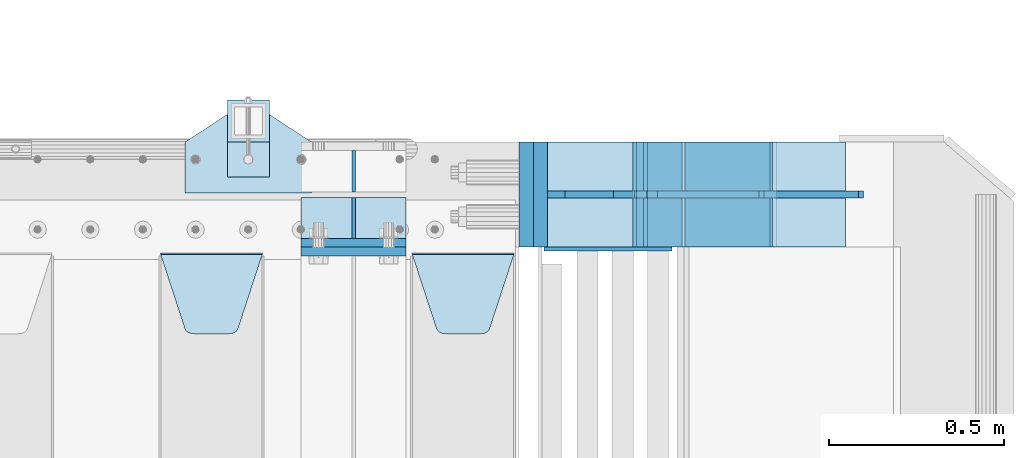
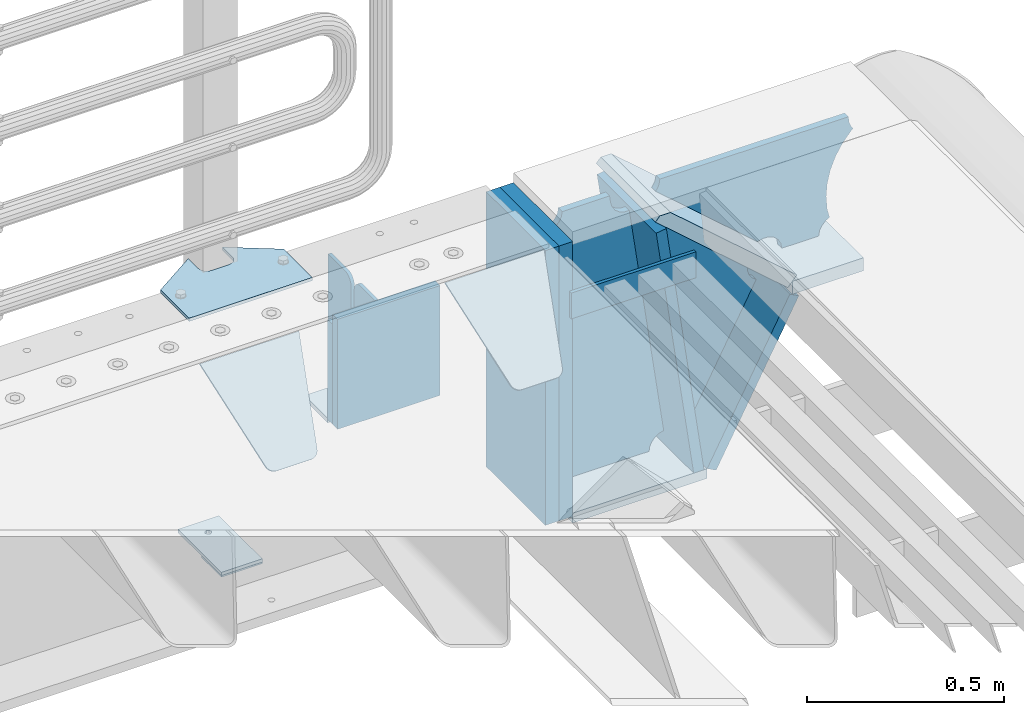
# One storey, part 227 of 240: 21 plates.
"""IFC2X3 building model written with IfcOpenShell, lengths in millimetres."""

import ifcopenshell
import ifcopenshell.guid

model = None  # the IFC model being written
_history = None  # IfcOwnerHistory: only IFC2X3 demands one
_inside = {}  # id of a spatial element -> (the spatial element, [elements in it])
_under = {}  # id of a project, library or spatial element -> (it, [spatial elements below it])
_declared = {}  # id of a project -> (the project, [libraries it declares])
_typed = {}  # id of a type object -> (the type object, [elements of that type])
_made_of = {}  # id of a material, layer set ... -> (it, [elements and type objects made of it])


def new_model(schema):
    """Start an empty IFC model of exactly this schema.

    Asked for "IFC4X3", IfcOpenShell would pick the latest addendum, in which some entities
    have other attributes; the version numbers below select the first issue.
    IFC2X3 requires an IfcOwnerHistory on every rooted entity: one is made here for all.
    """
    global model, _history
    if schema == "IFC4X3":
        model = ifcopenshell.file(schema_version=(4, 3, 0, 0))
    else:
        model = ifcopenshell.file(schema=schema)
    _inside.clear()
    _under.clear()
    _declared.clear()
    _typed.clear()
    _made_of.clear()
    _history = None
    if model.schema == "IFC2X3":
        org = make("IfcOrganization", Name="unknown")
        user = make(
            "IfcPersonAndOrganization",
            ThePerson=make("IfcPerson", FamilyName="unknown"),
            TheOrganization=org,
        )
        app = make(
            "IfcApplication",
            ApplicationDeveloper=org,
            Version="unknown",
            ApplicationFullName="unknown",
            ApplicationIdentifier="unknown",
        )
        _history = make(
            "IfcOwnerHistory",
            OwningUser=user,
            OwningApplication=app,
            ChangeAction="ADDED",
            CreationDate=0,
        )
    return model


def make(cls, **values):
    """One entity of the class cls with the attributes given. An attribute that is None is left unset."""
    return model.create_entity(
        cls, **{name: value for name, value in values.items() if value is not None}
    )


def rooted(cls, **values):
    """An entity with a GlobalId (a new one), such as an element, a storey or a relation."""
    return make(cls, GlobalId=ifcopenshell.guid.new(), OwnerHistory=_history, **values)


def si_unit(unit_type, name, prefix=None):
    """IfcSIUnit, for example si_unit("LENGTHUNIT", "METRE", prefix="MILLI")."""
    return make("IfcSIUnit", UnitType=unit_type, Prefix=prefix, Name=name)


def assignment(units):
    """IfcUnitAssignment: the units of a project."""
    return None if units is None else make("IfcUnitAssignment", Units=units)


def point(xyz):
    """IfcCartesianPoint."""
    return None if xyz is None else make("IfcCartesianPoint", Coordinates=xyz)


def direction(xyz):
    """IfcDirection."""
    return None if xyz is None else make("IfcDirection", DirectionRatios=xyz)


def frame(location, z_axis=None, x_axis=None):
    """IfcAxis2Placement3D, a coordinate frame: its origin and axes. An axis left out is left unset."""
    return make(
        "IfcAxis2Placement3D",
        Location=point(location),
        Axis=direction(z_axis),
        RefDirection=direction(x_axis),
    )


def origin_with_axes():
    """The frame at (0, 0, 0) with the z axis (0, 0, 1) and the x axis (1, 0, 0) written out."""
    return frame((0.0, 0.0, 0.0), z_axis=(0.0, 0.0, 1.0), x_axis=(1.0, 0.0, 0.0))


def place(relative_to, where):
    """IfcLocalPlacement: puts the frame where relative to a parent placement (None: the world)."""
    return make(
        "IfcLocalPlacement", PlacementRelTo=relative_to, RelativePlacement=where
    )


def context(
    kind, dimensions, precision=None, world=None, true_north=None, identifier=None
):
    """IfcGeometricRepresentationContext, for example the 3D "Model" context."""
    return make(
        "IfcGeometricRepresentationContext",
        ContextIdentifier=identifier,
        ContextType=kind,
        CoordinateSpaceDimension=dimensions,
        Precision=precision,
        WorldCoordinateSystem=world,
        TrueNorth=true_north,
    )


def subcontext(parent, identifier, kind, view, scale=None):
    """IfcGeometricRepresentationSubContext, for example "Body" below "Model"."""
    return make(
        "IfcGeometricRepresentationSubContext",
        ContextIdentifier=identifier,
        ContextType=kind,
        ParentContext=parent,
        TargetScale=scale,
        TargetView=view,
    )


def project(units=None, contexts=None):
    """IfcProject with its units and contexts."""
    return rooted(
        "IfcProject",
        Name="project",
        RepresentationContexts=contexts,
        UnitsInContext=assignment(units),
    )


def spatial(cls, under=None, at=None, **own):
    """A site, building, storey or space (cls), placed at a placement, below another one or the project."""
    s = rooted(cls, ObjectPlacement=at, **own)
    if under is not None:
        _under.setdefault(under.id(), (under, []))[1].append(s)
    return s


def faces_of(points, faces, orient=None, outer=None):
    """IfcFace entities. A face is a list of loops; a loop is a list of indices into points, from 0.

    orient and outer hold one flag for each loop. By default every Orientation is true, the
    first loop of a face is its IfcFaceOuterBound and the others are IfcFaceBound.
    """
    made = []
    for i, loops in enumerate(faces):
        bounds = []
        for j, loop in enumerate(loops):
            is_outer = j == 0 if outer is None else outer[i][j]
            bounds.append(
                make(
                    "IfcFaceOuterBound" if is_outer else "IfcFaceBound",
                    Bound=make("IfcPolyLoop", Polygon=[points[k] for k in loop]),
                    Orientation=True if orient is None else orient[i][j],
                )
            )
        made.append(make("IfcFace", Bounds=bounds))
    return made


def faceted_brep(points, faces, orient=None, outer=None, voids=None):
    """IfcFacetedBrep: a solid bounded by flat faces; with voids (closed shells), ...WithVoids."""
    shared = [point(p) for p in points]
    hull = make("IfcClosedShell", CfsFaces=faces_of(shared, faces, orient, outer))
    if voids is None:
        return make("IfcFacetedBrep", Outer=hull)
    return make(
        "IfcFacetedBrepWithVoids",
        Outer=hull,
        Voids=[
            make(cls, CfsFaces=faces_of(shared, fs, o, b)) for cls, fs, o, b in voids
        ],
    )


def shape(context_of_items, identifier, shape_type, items):
    """IfcShapeRepresentation: the items that make up one representation, for example the "Body"."""
    return make(
        "IfcShapeRepresentation",
        ContextOfItems=context_of_items,
        RepresentationIdentifier=identifier,
        RepresentationType=shape_type,
        Items=items,
    )


def material(Name=None, Category=None):
    """IfcMaterial."""
    return make("IfcMaterial", Name=Name, Category=Category)


def made_of(thing, what):
    """Note that an element or type object is made of a material, layer set ...; save() writes the relation."""
    if what is not None:
        _made_of.setdefault(what.id(), (what, []))[1].append(thing)
    return thing


def type_object(cls, material=None, **own):
    """A type object (cls), such as IfcWallType, which elements share."""
    return made_of(rooted(cls, **own), material)


def element(
    cls,
    number,
    at=None,
    inside=None,
    cuts=None,
    type_object=None,
    material=None,
    context=None,
    identifier="Body",
    shape_type=None,
    held_by="IfcProductDefinitionShape",
    body=None,
    shapes=None,
    **own,
):
    """One element of the class cls, such as IfcWall. Its Tag is "e" and its number.

    at: its placement. inside: the storey or other place that contains it. cuts: it is an
    opening in that element (IfcRelVoidsElement). A single representation is given by context,
    identifier, shape_type and body (its items); several are given by shapes. held_by: the class
    of the entity that holds the representations. save() writes the other relations.
    """
    e = rooted(cls, Tag="e%d" % number, ObjectPlacement=at, **own)
    if body is not None:
        shapes = [shape(context, identifier, shape_type, body)]
    if shapes is not None:
        e.Representation = make(held_by, Representations=shapes)
    if inside is not None:
        _inside.setdefault(inside.id(), (inside, []))[1].append(e)
    if cuts is not None:
        rooted(
            "IfcRelVoidsElement", RelatingBuildingElement=cuts, RelatedOpeningElement=e
        )
    if type_object is not None:
        _typed.setdefault(type_object.id(), (type_object, []))[1].append(e)
    return made_of(e, material)


def aggregate(whole, parts):
    """IfcRelAggregates: a whole, such as a stair, and the parts it consists of."""
    return rooted("IfcRelAggregates", RelatingObject=whole, RelatedObjects=parts)


def save(model, path):
    """Write the relations noted so far, then the file.

    IfcRelAggregates (storeys below a building ...), IfcRelContainedInSpatialStructure (elements
    in a storey), IfcRelDefinesByType, IfcRelAssociatesMaterial and IfcRelDeclares: one each for
    every whole, place, type object, material and project.
    """
    for whole, parts in _under.values():
        aggregate(whole, parts)
    for where, things in _inside.values():
        rooted(
            "IfcRelContainedInSpatialStructure",
            RelatedElements=things,
            RelatingStructure=where,
        )
    for kind, things in _typed.values():
        rooted("IfcRelDefinesByType", RelatedObjects=things, RelatingType=kind)
    for what, things in _made_of.values():
        rooted("IfcRelAssociatesMaterial", RelatedObjects=things, RelatingMaterial=what)
    for by, libraries in _declared.values():
        rooted("IfcRelDeclares", RelatingContext=by, RelatedDefinitions=libraries)
    model.write(path)


model = new_model("IFC2X3")

# Units and contexts
model_context = context("Model", 3, precision=1e-05, world=origin_with_axes())
body_context = subcontext(model_context, "Body", "Model", "MODEL_VIEW")
ifc_project = project(units=[si_unit("LENGTHUNIT", "METRE", prefix="MILLI"), si_unit("AREAUNIT", "SQUARE_METRE"), si_unit("VOLUMEUNIT", "CUBIC_METRE"), si_unit("MASSUNIT", "GRAM", prefix="KILO"), si_unit("TIMEUNIT", "SECOND"), si_unit("PLANEANGLEUNIT", "RADIAN"), si_unit("SOLIDANGLEUNIT", "STERADIAN"), si_unit("THERMODYNAMICTEMPERATUREUNIT", "DEGREE_CELSIUS"), si_unit("LUMINOUSINTENSITYUNIT", "LUMEN")], contexts=[model_context])

# Site, building, storey
site_placement = place(None, origin_with_axes())
site = spatial("IfcSite", under=ifc_project, at=site_placement, CompositionType="ELEMENT")
building_placement = place(site_placement, origin_with_axes())
building = spatial("IfcBuilding", under=site, at=building_placement, Name="Standard", CompositionType="ELEMENT")
storey_placement = place(building_placement, origin_with_axes())
storey = spatial("IfcBuildingStorey", under=building, at=storey_placement, Name="Undefined", CompositionType="ELEMENT", Elevation=0.0)

# Plates
ifc_material_1 = material(Name="STEEL/S355N")
plate_type_1 = type_object("IfcPlateType", PredefinedType="NOTDEFINED")
plate_1_placement = place(storey_placement, frame((55855.0, 35862.5, -339.999999999995), z_axis=(0.0, 0.0, 1.0), x_axis=(1.0, 0.0, 0.0)))
element("IfcPlate", 1, at=plate_1_placement, inside=storey, type_object=plate_type_1, material=ifc_material_1, context=body_context, shape_type="Brep", body=[
    faceted_brep([(0.0, -12.5, 0.0), (0.0, -12.5, 310.0), (0.0, 12.5, 310.0), (0.0, 12.5, 0.0), (300.0, -12.5, 310.0), (300.0, 12.5, 310.0), (300.0, -12.5, 0.0), (300.0, 12.5, 0.0)], [[[0, 1, 2, 3]], [[1, 4, 5, 2]], [[4, 6, 7, 5]], [[6, 0, 3, 7]], [[5, 7, 3, 2]], [[6, 4, 1, 0]]]),
])
plate_2_placement = place(storey_placement, frame((55855.0, 35837.5, -340.000000000044), z_axis=(0.0, 0.0, 1.0), x_axis=(1.0, 0.0, 0.0)))
element("IfcPlate", 2, at=plate_2_placement, inside=storey, type_object=plate_type_1, material=ifc_material_1, context=body_context, shape_type="Brep", body=[
    faceted_brep([(0.0, -12.5, 0.0), (9.31322574615479e-10, -12.5, 340.0), (9.31322574615479e-10, 12.5, 340.0), (0.0, 12.5, 0.0), (300.0, -12.5, 340.0), (300.0, 12.5, 340.0), (300.0, -12.5, 0.0), (300.0, 12.5, 0.0)], [[[0, 1, 2, 3]], [[1, 4, 5, 2]], [[4, 6, 7, 5]], [[6, 0, 3, 7]], [[5, 7, 3, 2]], [[6, 4, 1, 0]]]),
])
plate_type_2 = type_object("IfcPlateType", PredefinedType="NOTDEFINED")
plate_3_placement = place(storey_placement, frame((55855.0, 35992.0, -342.999999999995), z_axis=(0.0, -1.0, 0.0), x_axis=(1.0, 0.0, 0.0)))
element("IfcPlate", 3, at=plate_3_placement, inside=storey, type_object=plate_type_2, material=ifc_material_1, context=body_context, shape_type="Brep", body=[
    faceted_brep([(0.0, -7.0, 0.0), (0.0, -7.0, 117.0), (0.0, 7.0, 117.0), (0.0, 7.0, 0.0), (300.0, -7.0, 117.0), (300.0, 7.0, 117.0), (300.0, -7.0, 0.0), (300.0, 7.0, 0.0)], [[[0, 1, 2, 3]], [[1, 4, 5, 2]], [[4, 6, 7, 5]], [[6, 0, 3, 7]], [[5, 7, 3, 2]], [[6, 4, 1, 0]]]),
])
plate_type_3 = type_object("IfcPlateType", PredefinedType="NOTDEFINED")
for number, where, z_axis, x_axis in (
    (4, (56005.0, 36008.0, -29.9999999999945), (0.0, 0.0, -1.0), (0.0, 1.0, 0.0)),
    (5, (56005.0, 35992.0, -29.9999999999945), (0.0, 0.0, -1.0), (0.0, -1.0, 0.0)),
):
    element("IfcPlate", number, at=place(storey_placement, frame(where, z_axis=z_axis, x_axis=x_axis)), inside=storey, type_object=plate_type_3, material=ifc_material_1, context=body_context, shape_type="Brep", body=[
        faceted_brep([(0.0, -5.0, 30.0), (0.0, -5.0, 306.0), (0.0, 5.0, 306.0), (0.0, 5.0, 30.0), (117.0, -5.0, 306.0), (117.0, 5.0, 306.0), (117.0, -5.0, 0.0), (117.0, 5.0, 0.0), (30.0, -5.0, 0.0), (30.0, 5.0, 0.0), (24.7905546699913, -5.0, 0.455767409633758), (24.7905546699913, 5.0, 0.455767409633758), (19.7393957002278, -5.0, 1.80922137642275), (19.7393957002278, 5.0, 1.80922137642275), (15.0, -5.0, 4.01923788646684), (15.0, 5.0, 4.01923788646684), (10.7163717094008, -5.0, 7.01866670643066), (10.7163717094008, 5.0, 7.01866670643066), (7.01866670643358, -5.0, 10.7163717094038), (7.01866670643358, 5.0, 10.7163717094038), (4.01923788646673, -5.0, 15.0), (4.01923788646673, 5.0, 15.0), (1.80922137642483, -5.0, 19.7393957002299), (1.80922137642483, 5.0, 19.7393957002299), (0.455767409635882, -5.0, 24.7905546699921), (0.455767409635882, 5.0, 24.7905546699921)], [[[0, 1, 2, 3]], [[1, 4, 5, 2]], [[4, 6, 7, 5]], [[6, 8, 9, 7]], [[8, 10, 11, 9]], [[10, 12, 13, 11]], [[12, 14, 15, 13]], [[14, 16, 17, 15]], [[16, 18, 19, 17]], [[18, 20, 21, 19]], [[20, 22, 23, 21]], [[22, 24, 25, 23]], [[24, 0, 3, 25]], [[5, 7, 9, 11, 13, 15, 17, 19, 21, 23, 25, 3, 2]], [[24, 22, 20, 18, 16, 14, 12, 10, 8, 6, 4, 1, 0]]]),
    ])
plate_type_4 = type_object("IfcPlateType", PredefinedType="NOTDEFINED")
plate_4_placement = place(storey_placement, frame((56172.0, 35831.767766956, -1.76776695296758), z_axis=(0.0, -0.707106781186547, -0.707106781186548), x_axis=(1.0, 0.0, 0.0)))
element("IfcPlate", 6, at=plate_4_placement, inside=storey, type_object=plate_type_4, material=ifc_material_1, context=body_context, shape_type="Brep", body=[
    faceted_brep([(0.0, -2.5, 0.0), (69.345504679477, -2.50000000000364, 300.171731424827), (69.345504679477, 2.49999999999636, 300.171731424827), (0.0, 2.5, 0.0), (70.927406119954, -2.50000000000364, 304.897442415397), (70.927406119954, 2.49999999999636, 304.897442415397), (73.3818627772271, -2.50000000000728, 309.234538108525), (73.3818627772271, 2.49999999999636, 309.234538108529), (76.6187032999587, -2.50000000000728, 313.023683126099), (76.6187032999587, 2.49999999999636, 313.023683126103), (80.5190132705029, -2.50000000000364, 316.125672595368), (80.5190132705029, 2.49999999999636, 316.125672595368), (84.9395038596849, -2.50000000000364, 318.426546230472), (84.9395038596849, 2.49999999999636, 318.426546230472), (89.7177759439219, -2.5, 319.841774983277), (89.7177759439219, 2.49999999999636, 319.841774983273), (94.6782862926484, -2.50000000000364, 320.319366455074), (94.6782862926484, 2.49999999999636, 320.319366455074), (195.321713707352, -2.50000000000364, 320.319366455074), (195.321713707352, 2.49999999999636, 320.319366455074), (200.282224056078, -2.50000000000364, 319.841774983273), (200.282224056078, 2.49999999999636, 319.841774983273), (205.060496140315, -2.50000000000364, 318.426546230472), (205.060496140315, 2.49999999999636, 318.426546230472), (209.480986729497, -2.50000000000364, 316.125672595368), (209.480986729497, 2.49999999999636, 316.125672595368), (213.381296700041, -2.50000000000728, 313.023683126099), (213.381296700041, 2.49999999999272, 313.023683126099), (216.618137222766, -2.50000000000364, 309.234538108522), (216.618137222766, 2.49999999999636, 309.234538108522), (219.072593880039, -2.50000000000364, 304.897442415397), (219.072593880039, 2.49999999999636, 304.897442415397), (220.654495320523, -2.50000000000364, 300.171731424827), (220.654495320523, 2.49999999999636, 300.171731424827), (290.0, -2.50000000000364, -3.63797880709171e-12), (290.0, 2.49999999999636, -3.63797880709171e-12)], [[[0, 1, 2, 3]], [[1, 4, 5, 2]], [[4, 6, 7, 5]], [[6, 8, 9, 7]], [[8, 10, 11, 9]], [[10, 12, 13, 11]], [[12, 14, 15, 13]], [[14, 16, 17, 15]], [[16, 18, 19, 17]], [[18, 20, 21, 19]], [[20, 22, 23, 21]], [[22, 24, 25, 23]], [[24, 26, 27, 25]], [[26, 28, 29, 27]], [[28, 30, 31, 29]], [[30, 32, 33, 31]], [[32, 34, 35, 33]], [[34, 0, 3, 35]], [[5, 7, 9, 11, 13, 15, 17, 19, 21, 23, 25, 27, 29, 31, 33, 35, 3, 2]], [[34, 32, 30, 28, 26, 24, 22, 20, 18, 16, 14, 12, 10, 8, 6, 4, 1, 0]]]),
])
plate_5_placement = place(storey_placement, frame((55455.0, 35831.767766956, -1.76776695296758), z_axis=(0.0, -0.707106781186547, -0.707106781186548), x_axis=(1.0, 0.0, 0.0)))
element("IfcPlate", 7, at=plate_5_placement, inside=storey, type_object=plate_type_4, material=ifc_material_1, context=body_context, shape_type="Brep", body=[
    faceted_brep([(0.0, -2.5, 0.0), (69.345504679477, -2.50000000000364, 300.171731424827), (69.345504679477, 2.49999999999636, 300.171731424827), (0.0, 2.5, 0.0), (70.927406119954, -2.50000000000364, 304.897442415397), (70.927406119954, 2.49999999999636, 304.897442415397), (73.3818627772271, -2.50000000000728, 309.234538108525), (73.3818627772271, 2.49999999999636, 309.234538108529), (76.6187032999587, -2.50000000000728, 313.023683126099), (76.6187032999587, 2.49999999999636, 313.023683126103), (80.5190132705029, -2.50000000000364, 316.125672595368), (80.5190132705029, 2.49999999999636, 316.125672595368), (84.9395038596849, -2.50000000000364, 318.426546230472), (84.9395038596849, 2.49999999999636, 318.426546230472), (89.7177759439219, -2.5, 319.841774983277), (89.7177759439219, 2.49999999999636, 319.841774983273), (94.6782862926484, -2.50000000000364, 320.319366455074), (94.6782862926484, 2.49999999999636, 320.319366455074), (195.321713707352, -2.50000000000364, 320.319366455074), (195.321713707352, 2.49999999999636, 320.319366455074), (200.282224056078, -2.50000000000364, 319.841774983273), (200.282224056078, 2.49999999999636, 319.841774983273), (205.060496140315, -2.50000000000364, 318.426546230472), (205.060496140315, 2.49999999999636, 318.426546230472), (209.480986729497, -2.50000000000364, 316.125672595368), (209.480986729497, 2.49999999999636, 316.125672595368), (213.381296700041, -2.50000000000728, 313.023683126099), (213.381296700041, 2.49999999999272, 313.023683126099), (216.618137222766, -2.50000000000364, 309.234538108522), (216.618137222766, 2.49999999999636, 309.234538108522), (219.072593880039, -2.50000000000364, 304.897442415397), (219.072593880039, 2.49999999999636, 304.897442415397), (220.654495320523, -2.50000000000364, 300.171731424827), (220.654495320523, 2.49999999999636, 300.171731424827), (290.0, -2.50000000000364, -3.63797880709171e-12), (290.0, 2.49999999999636, -3.63797880709171e-12)], [[[0, 1, 2, 3]], [[1, 4, 5, 2]], [[4, 6, 7, 5]], [[6, 8, 9, 7]], [[8, 10, 11, 9]], [[10, 12, 13, 11]], [[12, 14, 15, 13]], [[14, 16, 17, 15]], [[16, 18, 19, 17]], [[18, 20, 21, 19]], [[20, 22, 23, 21]], [[22, 24, 25, 23]], [[24, 26, 27, 25]], [[26, 28, 29, 27]], [[28, 30, 31, 29]], [[30, 32, 33, 31]], [[32, 34, 35, 33]], [[34, 0, 3, 35]], [[5, 7, 9, 11, 13, 15, 17, 19, 21, 23, 25, 27, 29, 31, 33, 35, 3, 2]], [[34, 32, 30, 28, 26, 24, 22, 20, 18, 16, 14, 12, 10, 8, 6, 4, 1, 0]]]),
])
ifc_material_2 = material()
plate_type_5 = type_object("IfcPlateType", PredefinedType="NOTDEFINED")
plate_6_placement = place(storey_placement, frame((56497.0, 36150.0, -870.0), z_axis=(0.0, 0.0, 1.0), x_axis=(0.0, -1.0, 0.0)))
element("IfcPlate", 8, at=plate_6_placement, inside=storey, type_object=plate_type_5, material=ifc_material_2, context=body_context, shape_type="Brep", body=[
    faceted_brep([(0.0, -20.0, 0.0), (0.0, -20.0, 850.0), (0.0, 20.0, 850.0), (0.0, 20.0, 0.0), (300.0, -20.0, 850.0), (300.0, 20.0, 850.0), (300.0, -20.0, -1.81898940354586e-12), (300.0, 20.0, -1.81898940354586e-12)], [[[0, 1, 2, 3]], [[1, 4, 5, 2]], [[4, 6, 7, 5]], [[6, 0, 3, 7]], [[5, 7, 3, 2]], [[6, 4, 1, 0]]]),
])
plate_7_placement = place(storey_placement, frame((57198.9988298898, 36149.9999999992, -367.999999999302), z_axis=(-0.752989422949573, 0.0, 0.658032619955933), x_axis=(0.0, -1.0, 0.0)))
element("IfcPlate", 9, at=plate_7_placement, inside=storey, type_object=plate_type_5, material=ifc_material_1, context=body_context, shape_type="Brep", body=[
    faceted_brep([(-8.11269273981452e-10, 19.9999999999927, 490.766265601618), (0.0, -0.303811250945728, 514.0), (300.0, -0.303811250945728, 514.0), (300.0, 19.9999999999927, 490.766265601618), (300.0, -20.0, -1.81898940354586e-12), (300.0, -20.0, 514.0), (0.0, -20.0, 514.0), (0.0, -20.0, 0.0), (0.0, 20.0, 0.0), (300.0, 20.0, -1.81898940354586e-12)], [[[0, 1, 2, 3]], [[4, 5, 6, 7]], [[4, 7, 8, 9]], [[9, 8, 0, 3]], [[5, 4, 9, 3, 2]], [[6, 5, 2, 1]], [[8, 7, 6, 1, 0]]]),
])
plate_8_placement = place(storey_placement, frame((56536.9988298906, 36150.0, -870.000000000003), z_axis=(0.0, 0.0, 1.0), x_axis=(0.0, -1.0, 0.0)))
element("IfcPlate", 10, at=plate_8_placement, inside=storey, type_object=plate_type_5, material=ifc_material_2, context=body_context, shape_type="Brep", body=[
    faceted_brep([(0.0, -20.0, 0.0), (0.0, -20.0, 850.0), (0.0, 20.0, 850.0), (0.0, 20.0, 0.0), (300.0, -20.0, 850.0), (300.0, 20.0, 850.0), (300.0, -20.0, -1.81898940354586e-12), (300.0, 20.0, -1.81898940354586e-12)], [[[0, 1, 2, 3]], [[1, 4, 5, 2]], [[4, 6, 7, 5]], [[6, 0, 3, 7]], [[5, 7, 3, 2]], [[6, 4, 1, 0]]]),
])
ifc_material_3 = material(Name="STEEL/S355J2")
plate_type_6 = type_object("IfcPlateType", PredefinedType="NOTDEFINED")
plate_9_placement = place(storey_placement, frame((55525.0, 36005.0, 5.00000000004911), z_axis=(0.0, 1.0, 0.0), x_axis=(1.0, 0.0, 0.0)))
element("IfcPlate", 11, at=plate_9_placement, inside=storey, type_object=plate_type_6, material=ifc_material_3, context=body_context, shape_type="Brep", body=[
    faceted_brep([(0.0, -5.0, 0.0), (2.31396552408114e-06, -5.0, 145.0), (2.31396552408114e-06, 5.0, 145.0), (0.0, 5.0, 0.0), (130.0, -5.0, 230.0), (130.0, 5.0, 230.0), (130.0, -5.0, 180.0), (130.0, 5.0, 180.0), (130.48036798992, -5.0, 175.122741949599), (130.48036798992, 5.0, 175.122741949599), (131.903011687216, -5.0, 170.432914190875), (131.903011687216, 5.0, 170.432914190875), (134.213259692435, -5.0, 166.110744174512), (134.213259692435, 5.0, 166.110744174512), (137.322330470335, -5.0, 162.322330470335), (137.322330470335, 5.0, 162.322330470335), (141.110744174512, -5.0, 159.213259692435), (141.110744174512, 5.0, 159.213259692435), (145.432914190875, -5.0, 156.903011687216), (145.432914190875, 5.0, 156.903011687216), (150.122741949599, -5.0, 155.48036798992), (150.122741949599, 5.0, 155.48036798992), (155.0, -5.0, 155.0), (155.0, 5.0, 155.0), (205.0, -5.0, 155.0), (205.0, 5.0, 155.0), (209.877258050401, -5.0, 155.48036798992), (209.877258050401, 5.0, 155.48036798992), (214.567085809125, -5.0, 156.903011687216), (214.567085809125, 5.0, 156.903011687216), (218.889255825488, -5.0, 159.213259692435), (218.889255825488, 5.0, 159.213259692435), (222.677669529665, -5.0, 162.322330470335), (222.677669529665, 5.0, 162.322330470335), (225.786740307565, -5.0, 166.110744174512), (225.786740307565, 5.0, 166.110744174512), (228.096988312784, -5.0, 170.432914190875), (228.096988312784, 5.0, 170.432914190875), (229.51963201008, -5.0, 175.122741949599), (229.51963201008, 5.0, 175.122741949599), (230.0, -5.0, 180.0), (230.0, 5.0, 180.0), (230.0, -5.0, 230.0), (230.0, 5.0, 230.0), (360.0, -5.0, 145.0), (360.0, 5.0, 145.0), (360.0, -5.0, -7.27595761418343e-12), (360.0, 5.0, -7.27595761418343e-12)], [[[0, 1, 2, 3]], [[1, 4, 5, 2]], [[4, 6, 7, 5]], [[6, 8, 9, 7]], [[8, 10, 11, 9]], [[10, 12, 13, 11]], [[12, 14, 15, 13]], [[14, 16, 17, 15]], [[16, 18, 19, 17]], [[18, 20, 21, 19]], [[20, 22, 23, 21]], [[22, 24, 25, 23]], [[24, 26, 27, 25]], [[26, 28, 29, 27]], [[28, 30, 31, 29]], [[30, 32, 33, 31]], [[32, 34, 35, 33]], [[34, 36, 37, 35]], [[36, 38, 39, 37]], [[38, 40, 41, 39]], [[40, 42, 43, 41]], [[42, 44, 45, 43]], [[44, 46, 47, 45]], [[46, 0, 3, 47]], [[5, 7, 9, 11, 13, 15, 17, 19, 21, 23, 25, 27, 29, 31, 33, 35, 37, 39, 41, 43, 45, 47, 3, 2]], [[46, 44, 42, 40, 38, 36, 34, 32, 30, 28, 26, 24, 22, 20, 18, 16, 14, 12, 10, 8, 6, 4, 1, 0]]]),
])
plate_type_7 = type_object("IfcPlateType", PredefinedType="NOTDEFINED")
plate_10_placement = place(storey_placement, frame((55645.0000000001, 36050.0000000002, -850.000000000002), z_axis=(0.0, 1.0, 0.0), x_axis=(1.0, 0.0, 0.0)))
element("IfcPlate", 12, at=plate_10_placement, inside=storey, type_object=plate_type_7, material=ifc_material_3, context=body_context, shape_type="Brep", body=[
    faceted_brep([(66.3639610305399, -5.0, 163.636038969111), (66.3639610305399, 5.0, 163.636038969111), (59.9999999998618, 5.0, 160.999999999789), (59.9999999998618, -5.0, 160.999999999789), (53.6360389691836, 5.0, 163.636038969111), (53.6360389691836, -5.0, 163.636038969111), (50.9999999998618, 5.0, 169.999999999789), (50.9999999998618, -5.0, 169.999999999789), (53.6360389691836, 5.0, 176.363961030467), (53.6360389691836, -5.0, 176.363961030467), (59.9999999998618, 5.0, 178.999999999789), (59.9999999998618, -5.0, 178.999999999789), (66.3639610305399, 5.0, 176.363961030467), (66.3639610305399, -5.0, 176.363961030467), (68.9999999998618, 5.0, 169.999999999789), (68.9999999998618, -5.0, 169.999999999789), (120.0, -5.0, 0.0), (120.0, -5.0, 220.0), (0.0, -5.0, 220.0), (0.0, -5.0, 0.0), (0.0, 5.0, 0.0), (120.0, 5.0, 0.0), (120.0, 5.0, 220.0), (0.0, 5.0, 220.0)], [[[0, 1, 2, 3]], [[3, 2, 4, 5]], [[5, 4, 6, 7]], [[7, 6, 8, 9]], [[9, 8, 10, 11]], [[11, 10, 12, 13]], [[13, 12, 14, 15]], [[15, 14, 1, 0]], [[16, 17, 18, 19], [3, 5, 7, 9, 11, 13, 15, 0]], [[16, 19, 20, 21]], [[17, 16, 21, 22]], [[18, 17, 22, 23]], [[19, 18, 23, 20]], [[22, 21, 20, 23], [10, 8, 6, 4, 2, 1, 14, 12]]]),
])
plate_type_8 = type_object("IfcPlateType", PredefinedType="NOTDEFINED")
plate_11_placement = place(storey_placement, frame((55645.0000000001, 36050.0000000002, -857.500000000002), z_axis=(0.0, 1.0, 0.0), x_axis=(1.0, 0.0, 0.0)))
element("IfcPlate", 13, at=plate_11_placement, inside=storey, type_object=plate_type_8, material=ifc_material_3, context=body_context, shape_type="Brep", body=[
    faceted_brep([(0.0, -2.5, 0.0), (0.0, -2.5, 100.0), (0.0, 2.5, 100.0), (0.0, 2.5, 0.0), (120.0, -2.5, 100.0), (120.0, 2.5, 100.0), (120.0, -2.5, 0.0), (120.0, 2.5, 0.0)], [[[0, 1, 2, 3]], [[1, 4, 5, 2]], [[4, 6, 7, 5]], [[6, 0, 3, 7]], [[5, 7, 3, 2]], [[6, 4, 1, 0]]]),
])
plate_type_9 = type_object("IfcPlateType", PredefinedType="NOTDEFINED")
plate_12_placement = place(storey_placement, frame((57198.9988298898, 35849.9999999992, -387.999999999302), z_axis=(1.0, 0.0, 0.0), x_axis=(0.0, 1.0, 0.0)))
element("IfcPlate", 14, at=plate_12_placement, inside=storey, type_object=plate_type_9, material=ifc_material_1, context=body_context, shape_type="Brep", body=[
    faceted_brep([(0.0, -20.0, 0.0), (3.31056071445346e-10, -20.0, 208.0), (3.31056071445346e-10, 20.0, 208.0), (0.0, 20.0, 0.0), (300.0, -20.0, 208.0), (300.0, 20.0, 208.0), (300.0, -20.0, -1.81898940354586e-12), (300.0, 20.0, -1.81898940354586e-12)], [[[0, 1, 2, 3]], [[1, 4, 5, 2]], [[4, 6, 7, 5]], [[6, 0, 3, 7]], [[5, 7, 3, 2]], [[6, 4, 1, 0]]]),
])
plate_type_10 = type_object("IfcPlateType", PredefinedType="NOTDEFINED")
plate_13_placement = place(storey_placement, frame((56949.9988298891, 36150.0, -875.000000003253), z_axis=(0.0, -1.0, 0.0), x_axis=(-1.0, 0.0, 0.0)))
element("IfcPlate", 15, at=plate_13_placement, inside=storey, type_object=plate_type_10, material=ifc_material_1, context=body_context, shape_type="Brep", body=[
    faceted_brep([(0.0, -15.0, 0.0), (0.0, -15.0, 300.0), (0.0, 15.0, 300.0), (0.0, 15.0, 0.0), (393.0, -15.0, 300.0), (393.0, 15.0, 300.0), (393.0, -15.0, 0.0), (393.0, 15.0, 0.0)], [[[0, 1, 2, 3]], [[1, 4, 5, 2]], [[4, 6, 7, 5]], [[6, 0, 3, 7]], [[5, 7, 3, 2]], [[6, 4, 1, 0]]]),
])
plate_14_placement = place(storey_placement, frame((56926.1480677219, 36150.000000001, -862.083788721732), z_axis=(-0.139173011053008, 0.0, 0.990268081377179), x_axis=(0.0, -1.0, 0.0)))
element("IfcPlate", 16, at=plate_14_placement, inside=storey, type_object=plate_type_10, material=ifc_material_1, context=body_context, shape_type="Brep", body=[
    faceted_brep([(1.00408215075731e-09, 14.9994702460463, -0.00376939772468177), (300.0, 15.0, 0.0), (300.0, -15.0, 4.21237841381662), (0.0, -15.0, 4.21237841381662), (0.0, -15.0, 792.000000000001), (300.0, -15.0, 792.000000000001), (300.0, 14.9999999999927, 792.000000000001), (0.0, 14.9999999999927, 792.000000000001)], [[[0, 1, 2, 3]], [[4, 5, 6, 7]], [[4, 7, 0, 3]], [[5, 4, 3, 2]], [[6, 5, 2, 1]], [[7, 6, 1, 0]]]),
])
plate_15_placement = place(storey_placement, frame((56963.2468009566, 36150.000000001, -867.038754739308), z_axis=(0.469471552246179, 0.0, 0.882947598462991), x_axis=(0.0, -1.0, 0.0)))
element("IfcPlate", 17, at=plate_15_placement, inside=storey, type_object=plate_type_10, material=ifc_material_1, context=body_context, shape_type="Brep", body=[
    faceted_brep([(0.0, -15.0, 0.0), (0.0, -15.0, 514.999999999996), (0.0, 15.0, 515.0), (0.0, 15.0, 0.0), (300.0, -15.0, 514.999999999996), (300.0, 15.0, 515.0), (300.0, -15.0, 0.0), (300.0, 15.0, 0.0)], [[[0, 1, 2, 3]], [[1, 4, 5, 2]], [[4, 6, 7, 5]], [[6, 0, 3, 7]], [[5, 7, 3, 2]], [[6, 4, 1, 0]]]),
])
plate_type_11 = type_object("IfcPlateType", PredefinedType="NOTDEFINED")
plate_16_placement = place(storey_placement, frame((57513.9988298898, 35999.9999999994, -29.9999999993023), z_axis=(-0.000446694000102124, 0.0, -0.99999990023223), x_axis=(-0.99999990023223, 0.0, 0.000446694000103734)))
element("IfcPlate", 18, at=plate_16_placement, inside=storey, type_object=plate_type_11, material=ifc_material_1, context=body_context, shape_type="Brep", body=[
    faceted_brep([(125.007775472986, 10.0, 291.842314882028), (131.755016800053, 10.0, 263.793234614468), (131.755016800053, -10.0, 263.793234614468), (125.007775472986, -10.0, 291.842314882028), (134.899927074475, 10.0, 224.060281342732), (134.899927074475, -10.0, 224.060281342732), (131.79051499522, 10.0, 184.324534302446), (131.79051499522, -10.0, 184.324534302446), (122.503344607205, 10.0, 145.564419461128), (122.503344607205, -10.0, 145.564419461128), (107.267096867748, 10.0, 108.734339483615), (107.267096867748, -10.0, 108.734339483615), (86.4569387623924, 10.0, 74.7411731709829), (86.4569387623924, -10.0, 74.7411731709829), (60.5852854486438, 10.0, 44.4219450946983), (60.5852854486438, -10.0, 44.4219450946983), (56.2519855253122, 10.0, 40.7176084148918), (56.2519855253122, -10.0, 40.7176084148918), (136.409234539125, -10.0, 297.721677540594), (147.386991180589, -10.0, 308.778803581017), (147.386991180589, 10.0, 308.778803581017), (136.409234539125, 10.0, 297.721677540594), (154.42816613277, -10.0, 322.678193223937), (154.42816613277, 10.0, 322.678193223937), (156.849001662988, -10.0, 338.070097995228), (156.849001662988, 10.0, 338.070097995228), (264.849004013297, -10.0, 338.118348049693), (264.849004013297, 10.0, 338.118348049693), (267.628767119553, -10.0, 321.701412969031), (267.628767119553, 10.0, 321.701412969031), (275.645118712178, -10.0, 307.107546191754), (275.645118712178, 10.0, 307.107546191754), (288.009068357213, -10.0, 295.955165748785), (288.009068357213, 10.0, 295.955165748785), (303.34948944753, -10.0, 289.481038692482), (303.34948944753, 10.0, 289.481038692482), (319.965173216937, -10.0, 288.403127172445), (319.965173216937, 10.0, 288.403127172445), (336.013487920238, -10.0, 292.840968489265), (336.013487920238, 10.0, 292.840968489265), (335.869079589851, -10.0, 293.150054931641), (335.869079589851, 10.0, 293.150054931641), (633.937057436444, -10.0, 32.8861672876965), (633.937057436444, 10.0, 32.8861672876965), (628.672097726398, -10.0, 25.6357574923157), (628.672097726398, 10.0, 25.6357574923157), (624.785781531275, -10.0, 17.5620477266101), (624.785781531275, 10.0, 17.5620477266101), (622.402919050612, -10.0, 8.92432757904926), (622.402919050612, 10.0, 8.92432757904926), (621.600036621094, -10.0, -8.74677219542264e-10), (621.600036621094, 10.0, -8.74677219542264e-10), (70.0000000000073, -10.0, -9.84945458526454e-11), (70.0000000000073, 10.0, -9.84945458526454e-11), (67.7728137216618, -10.0, 17.5170123094482), (67.7728137216618, 10.0, 17.5170123094482), (61.2329794214093, -10.0, 33.9193489203215), (61.2329794214093, 10.0, 33.9193489203215)], [[[0, 1, 2, 3]], [[4, 5, 2, 1]], [[6, 7, 5, 4]], [[8, 9, 7, 6]], [[10, 11, 9, 8]], [[12, 13, 11, 10]], [[14, 15, 13, 12]], [[16, 17, 15, 14]], [[18, 19, 20, 21]], [[19, 22, 23, 20]], [[22, 24, 25, 23]], [[24, 26, 27, 25]], [[26, 28, 29, 27]], [[28, 30, 31, 29]], [[30, 32, 33, 31]], [[32, 34, 35, 33]], [[34, 36, 37, 35]], [[36, 38, 39, 37]], [[38, 40, 41, 39]], [[40, 42, 43, 41]], [[42, 44, 45, 43]], [[44, 46, 47, 45]], [[46, 48, 49, 47]], [[48, 50, 51, 49]], [[50, 52, 53, 51]], [[52, 54, 55, 53]], [[54, 56, 57, 55]], [[12, 10, 8, 6, 4, 1, 0, 21, 20, 23, 25, 27, 29, 31, 33, 35, 37, 39, 41, 43, 45, 47, 49, 51, 53, 55, 57, 16, 14]], [[18, 21, 0, 3]], [[56, 54, 52, 50, 48, 46, 44, 42, 40, 38, 36, 34, 32, 30, 28, 26, 24, 22, 19, 18, 3, 2, 5, 7, 9, 11, 13, 15, 17]], [[57, 56, 17, 16]]]),
])
plate_type_12 = type_object("IfcPlateType", PredefinedType="NOTDEFINED")
plate_17_placement = place(storey_placement, frame((57198.0025685034, 36000.000000001, -393.996688204407), z_axis=(-0.658066357015093, 0.0, -0.752959939017266), x_axis=(-0.752959939017268, 0.0, 0.65806635701509)))
element("IfcPlate", 19, at=plate_17_placement, inside=storey, type_object=plate_type_12, material=ifc_material_1, context=body_context, shape_type="Brep", body=[
    faceted_brep([(-11.3595226159669, -10.0, 48.6925173505806), (-112.015767301033, -10.0, 480.154833723624), (-112.015767301033, 10.0, 480.154833723624), (-11.3595226159669, 10.0, 48.6925173505806), (-104.567323293646, -10.0, 482.519601382526), (-104.567323293646, 10.0, 482.519601382526), (-97.5783311600098, -10.0, 486.016090073739), (-97.5783311600098, 10.0, 486.016090073739), (-91.2195220373906, -10.0, 490.558885551647), (-91.2195220373906, 10.0, 490.558885551647), (-85.6462325884277, -10.0, 496.037013783993), (-85.6462325884277, 10.0, 496.037013783993), (447.024482710491, -10.0, 32.8103372896294), (447.024482710491, 10.0, 32.8103372896294), (441.786973010385, -10.0, 25.5709623937219), (441.786973010385, 10.0, 25.5709623937219), (437.921644570124, -10.0, 17.5149526624009), (437.921644570124, 10.0, 17.5149526624009), (435.551940606492, -10.0, 8.89958500531066), (435.551940606492, 10.0, 8.89958500531066), (434.753540039055, -10.0, -5.23868948221207e-10), (434.753540039055, 10.0, -5.23868948221207e-10), (50.0, -10.0, 0.0), (50.0, 10.0, 0.0), (47.7668538974176, -10.0, 14.7759151575083), (47.7668538974176, 10.0, 14.7759151575083), (41.2668932502784, -10.0, 28.231959221237), (41.2668932502784, 10.0, 28.231959221237), (31.080732530012, -10.0, 39.1661596968188), (31.080732530012, 10.0, 39.1661596968188), (18.1182591411416, -10.0, 46.6018098971836), (18.1182591411416, 10.0, 46.6018098971836), (3.53735696079821, -10.0, 49.8747140917258), (3.53735696079821, 10.0, 49.8747140917258)], [[[0, 1, 2, 3]], [[1, 4, 5, 2]], [[4, 6, 7, 5]], [[6, 8, 9, 7]], [[8, 10, 11, 9]], [[10, 12, 13, 11]], [[12, 14, 15, 13]], [[14, 16, 17, 15]], [[16, 18, 19, 17]], [[18, 20, 21, 19]], [[20, 22, 23, 21]], [[22, 24, 25, 23]], [[24, 26, 27, 25]], [[26, 28, 29, 27]], [[28, 30, 31, 29]], [[30, 32, 33, 31]], [[32, 0, 3, 33]], [[5, 7, 9, 11, 13, 15, 17, 19, 21, 23, 25, 27, 29, 31, 33, 3, 2]], [[32, 30, 28, 26, 24, 22, 20, 18, 16, 14, 12, 10, 8, 6, 4, 1, 0]]]),
])
plate_type_13 = type_object("IfcPlateType", PredefinedType="NOTDEFINED")
plate_18_placement = place(storey_placement, frame((56795.998829889, 36000.0, -30.0000000032531), z_axis=(0.0, 0.0, -1.0), x_axis=(-1.0, 0.0, 0.0)))
element("IfcPlate", 20, at=plate_18_placement, inside=storey, type_object=plate_type_13, material=ifc_material_1, context=body_context, shape_type="Brep", body=[
    faceted_brep([(-9.00602409638668, -10.0, 65.0), (-108.137843376921, -10.0, 780.473130459514), (-108.137843376921, 10.0, 780.473130459514), (-9.00602409638668, 10.0, 65.0), (-94.4157884488377, -10.0, 784.433672138112), (-94.4157884488377, 10.0, 784.433672138112), (-82.3732461236723, -10.0, 792.112074067144), (-82.3732461236723, 10.0, 792.112074067144), (-72.9927947992401, -10.0, 802.881837982249), (-72.9927947992401, 10.0, 802.881837982249), (-67.0398068183713, -10.0, 815.864234368775), (-67.0398068183713, 10.0, 815.864234368775), (-65.0, -10.0, 830.0), (-65.0, 10.0, 830.0), (189.0, -10.0, 830.0), (189.0, 10.0, 830.0), (191.447174185239, -10.0, 814.549150281253), (191.447174185239, 10.0, 814.549150281253), (198.549150281251, -10.0, 800.610737385376), (198.549150281251, 10.0, 800.610737385376), (209.610737385374, -10.0, 789.549150281253), (209.610737385374, 10.0, 789.549150281253), (223.549150281251, -10.0, 782.447174185242), (223.549150281251, 10.0, 782.447174185242), (239.0, -10.0, 780.0), (239.0, 10.0, 780.0), (239.0, -10.0, 50.0), (239.0, 10.0, 50.0), (223.549150281251, -10.0, 47.5528258147577), (223.549150281251, 10.0, 47.5528258147577), (209.610737385374, -10.0, 40.4508497187474), (209.610737385374, 10.0, 40.4508497187474), (198.549150281251, -10.0, 29.3892626146237), (198.549150281251, 10.0, 29.3892626146237), (191.447174185239, -10.0, 15.4508497187474), (191.447174185239, 10.0, 15.4508497187474), (189.0, -10.0, 0.0), (189.0, 10.0, 0.0), (50.4776502774184, -10.0, 0.0), (50.4776502774184, 10.0, 0.0), (47.3830020671812, -10.0, 22.3352870825933), (47.3830020671812, 10.0, 22.3352870825933), (42.8384615202813, -10.0, 37.3040735979326), (42.8384615202813, 10.0, 37.3040735979326), (33.8907372011745, -10.0, 50.1358952937587), (33.8907372011745, 10.0, 50.1358952937587), (21.415694708674, -10.0, 59.5746840579253), (21.415694708674, 10.0, 59.5746840579253), (6.63447812067898, -10.0, 64.6965054822873), (6.63447812067898, 10.0, 64.6965054822873)], [[[0, 1, 2, 3]], [[1, 4, 5, 2]], [[4, 6, 7, 5]], [[6, 8, 9, 7]], [[8, 10, 11, 9]], [[10, 12, 13, 11]], [[12, 14, 15, 13]], [[14, 16, 17, 15]], [[16, 18, 19, 17]], [[18, 20, 21, 19]], [[20, 22, 23, 21]], [[22, 24, 25, 23]], [[24, 26, 27, 25]], [[26, 28, 29, 27]], [[28, 30, 31, 29]], [[30, 32, 33, 31]], [[32, 34, 35, 33]], [[34, 36, 37, 35]], [[36, 38, 39, 37]], [[38, 40, 41, 39]], [[40, 42, 43, 41]], [[42, 44, 45, 43]], [[44, 46, 47, 45]], [[46, 48, 49, 47]], [[48, 0, 3, 49]], [[5, 7, 9, 11, 13, 15, 17, 19, 21, 23, 25, 27, 29, 31, 33, 35, 37, 39, 41, 43, 45, 47, 49, 3, 2]], [[48, 46, 44, 42, 40, 38, 36, 34, 32, 30, 28, 26, 24, 22, 20, 18, 16, 14, 12, 10, 8, 6, 4, 1, 0]]]),
])
plate_type_14 = type_object("IfcPlateType", PredefinedType="NOTDEFINED")
plate_19_placement = place(storey_placement, frame((56911.998829901, 35844.9999004229, -249.999999999564), z_axis=(-1.0, 0.0, 0.0), x_axis=(0.0, 0.0, 1.0)))
element("IfcPlate", 21, at=plate_19_placement, inside=storey, type_object=plate_type_14, material=ifc_material_1, context=body_context, shape_type="Brep", body=[
    faceted_brep([(0.0, -5.0, 0.0), (0.0, -5.0, 365.0), (0.0, 5.0, 365.0), (0.0, 5.0, 0.0), (80.0, -5.0, 365.0), (80.0, 5.0, 365.0), (80.0, -5.0, 0.0), (80.0, 5.0, 0.0)], [[[0, 1, 2, 3]], [[1, 4, 5, 2]], [[4, 6, 7, 5]], [[6, 0, 3, 7]], [[5, 7, 3, 2]], [[6, 4, 1, 0]]]),
])

save(model, "model.ifc")
